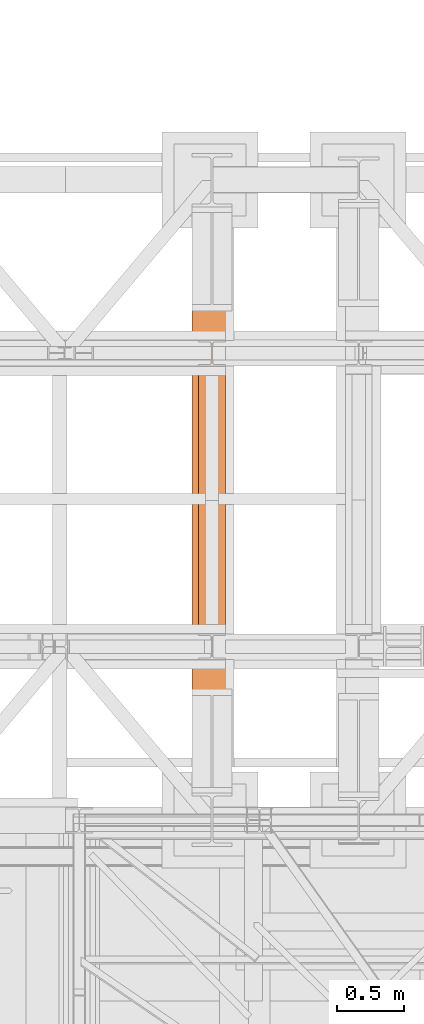
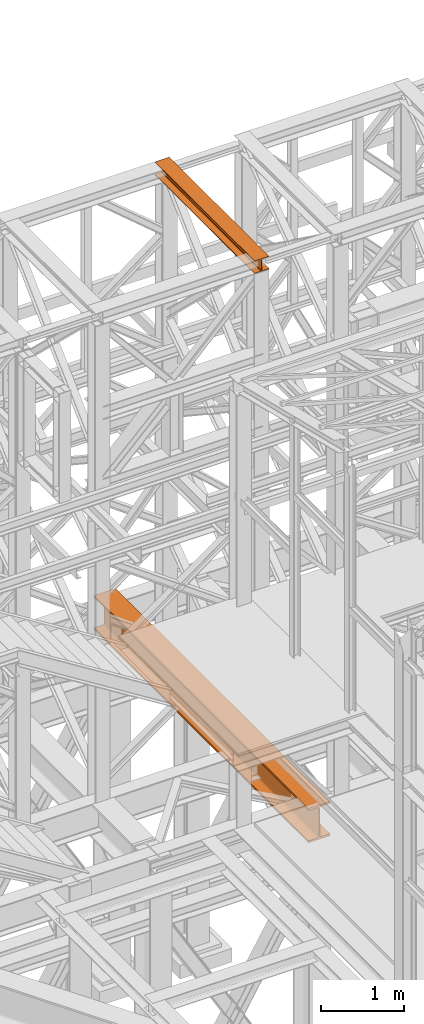
# One storey, part 121 of 208: 2 proxies.
"""IFC2X3 building model written with IfcOpenShell, lengths in millimetres."""

from ifc_helpers import new_model, entity, si_unit, converted_unit, frame, origin, origin_with_axes, place, context, subcontext, project, spatial, faceted_brep, element, save


model = new_model("IFC2X3")

# Units and contexts
model_context = context("Model", 3, precision=1e-05, world=origin())
plan_context = context("Plan", 3, precision=1e-05, world=origin())
body_context = subcontext(model_context, "Body", "Model", "MODEL_VIEW")
ifc_project = project(units=[si_unit("LENGTHUNIT", "METRE", prefix="MILLI"), converted_unit("PLANEANGLEUNIT", "DEGREE", entity("IfcPlaneAngleMeasure", 0.0174532925199433), si_unit("PLANEANGLEUNIT", "RADIAN"), dimensions=[0, 0, 0, 0, 0, 0, 0]), si_unit("AREAUNIT", "SQUARE_METRE"), si_unit("VOLUMEUNIT", "CUBIC_METRE")], contexts=[model_context, plan_context])

# Building, storey
building_placement = place(None, origin())
building = spatial("IfcBuilding", under=ifc_project, at=building_placement, CompositionType="COMPLEX")
storey_placement = place(building_placement, origin_with_axes())
storey = spatial("IfcBuildingStorey", under=building, at=storey_placement, Name="Geschoss", CompositionType="ELEMENT")

# Proxies
proxy_1_placement = place(storey_placement, frame((2043.254974489131, -17432.57439531566, 4784.990005364415), z_axis=(0.0, 0.0, 1.0), x_axis=(1.0, 0.0, 0.0)))
element("IfcBuildingElementProxy", 1, at=proxy_1_placement, inside=storey, context=body_context, shape_type="Brep", body=[
    faceted_brep([(300.0100000000002, 0.01000000000203727, 500.0100000000002), (300.0100000000007, 5140.010003576277, 500.0100000000002), (300.0100000000007, 5140.010003576277, 472.0100000000002), (300.0100000000002, 0.01000000000203727, 472.0100000000002), (300.0100000000002, 0.01000000000203727, 472.0100000000002), (300.0100000000007, 5140.010003576277, 472.0100000000002), (184.2600000000007, 5140.010003576277, 472.0100000000002), (184.2600000000002, 0.01000000000203727, 472.0100000000002), (184.2600000000002, 0.01000000000203727, 472.0100000000002), (184.2600000000007, 5140.010003576277, 472.0100000000002), (177.271909219226, 5140.010003576277, 471.0899181875066), (177.2719092192256, 0.01000000000203727, 471.0899181875066), (177.2719092192256, 0.01000000000203727, 471.0899181875066), (177.271909219226, 5140.010003576277, 471.0899181875066), (170.7600393754606, 5140.010003576277, 468.3926133818113), (170.7600393754601, 0.01000000000203727, 468.3926133818113), (170.7600393754601, 0.01000000000203727, 468.3926133818113), (170.7600393754606, 5140.010003576277, 468.3926133818113), (165.1681169079661, 5140.010003576277, 464.1018830920375), (165.1681169079657, 0.01000000000203727, 464.1018830920366), (165.1681169079657, 0.01000000000203727, 464.1018830920366), (165.1681169079661, 5140.010003576277, 464.1018830920375), (160.8773866181896, 5140.010003576277, 458.5099606245422), (160.8773866181891, 0.01000000000203727, 458.5099606245422), (160.8773866181891, 0.01000000000203727, 458.5099606245422), (160.8773866181896, 5140.010003576277, 458.5099606245422), (158.1800818124962, 5140.010003576277, 451.9980907807767), (158.1800818124957, 0.01000000000203727, 451.9980907807767), (158.1800818124957, 0.01000000000203727, 451.9980907807767), (158.1800818124962, 5140.010003576277, 451.9980907807767), (157.2600000000007, 5140.010003576277, 445.0100000000002), (157.2600000000002, 0.01000000000203727, 445.0100000000002), (157.2600000000002, 0.01000000000203727, 445.0100000000002), (157.2600000000007, 5140.010003576277, 445.0100000000002), (157.2600000000007, 5140.010003576277, 55.01000000000022), (157.2600000000002, 0.01000000000203727, 55.01000000000022), (157.2600000000002, 0.01000000000203727, 55.01000000000022), (157.2600000000007, 5140.010003576277, 55.01000000000022), (158.5815660577414, 5140.010003576277, 46.66656945413979), (158.5815660577409, 0.01000000000203727, 46.66656945413979), (158.5815660577409, 0.01000000000203727, 46.66656945413979), (158.5815660577414, 5140.010003576277, 46.66656945413979), (162.4165745365995, 5140.010003576277, 39.13982493419917), (162.416574536599, 0.01000000000203727, 39.13982493419917), (162.416574536599, 0.01000000000203727, 39.13982493419917), (162.4165745365995, 5140.010003576277, 39.13982493419917), (168.3898249342005, 5140.010003576277, 33.16657453659809), (168.3898249342001, 0.01000000000203727, 33.16657453659809), (168.3898249342001, 0.01000000000203727, 33.16657453659809), (168.3898249342005, 5140.010003576277, 33.16657453659809), (175.9165694541393, 5140.010003576277, 29.33156605774093), (175.9165694541389, 0.01000000000203727, 29.33156605774093), (175.9165694541389, 0.01000000000203727, 29.33156605774093), (175.9165694541393, 5140.010003576277, 29.33156605774093), (184.2600000000007, 5140.010003576277, 28.01000000000022), (184.2600000000002, 0.01000000000203727, 28.01000000000022), (184.2600000000002, 0.01000000000203727, 28.01000000000022), (184.2600000000007, 5140.010003576277, 28.01000000000022), (300.0100000000007, 5140.010003576277, 28.01000000000022), (300.0100000000002, 0.01000000000203727, 28.01000000000022), (300.0100000000002, 0.01000000000203727, 28.01000000000022), (300.0100000000007, 5140.010003576277, 28.01000000000022), (300.0100000000007, 5140.010003576277, 0.01000000000021828), (300.0100000000002, 0.01000000000203727, 0.01000000000021828), (300.0100000000002, 0.01000000000203727, 0.01000000000021828), (300.0100000000007, 5140.010003576277, 0.01000000000021828), (0.0100000000009004, 5140.010003576277, 0.01000000000021828), (0.01000000000021828, 0.01000000000203727, 0.01000000000021828), (0.01000000000021828, 0.01000000000203727, 0.01000000000021828), (0.0100000000009004, 5140.010003576277, 0.01000000000021828), (0.0100000000009004, 5140.010003576277, 28.01000000000022), (0.01000000000021828, 0.01000000000203727, 28.01000000000022), (0.01000000000021828, 0.01000000000203727, 28.01000000000022), (0.0100000000009004, 5140.010003576277, 28.01000000000022), (115.7600000000007, 5140.010003576277, 28.01000000000022), (115.7600000000002, 0.01000000000203727, 28.01000000000022), (115.7600000000002, 0.01000000000203727, 28.01000000000022), (115.7600000000007, 5140.010003576277, 28.01000000000022), (124.103430545862, 5140.010003576277, 29.33156605774093), (124.1034305458616, 0.01000000000203727, 29.33156605774093), (124.1034305458616, 0.01000000000203727, 29.33156605774093), (124.103430545862, 5140.010003576277, 29.33156605774093), (131.6301750658045, 5140.010003576277, 33.16657453659809), (131.630175065804, 0.01000000000203727, 33.16657453659809), (131.630175065804, 0.01000000000203727, 33.16657453659809), (131.6301750658045, 5140.010003576277, 33.16657453659809), (137.6034254634019, 5140.010003576277, 39.13982493419917), (137.6034254634014, 0.01000000000203727, 39.13982493419917), (137.6034254634014, 0.01000000000203727, 39.13982493419917), (137.6034254634019, 5140.010003576277, 39.13982493419917), (141.43843394226, 5140.010003576277, 46.66656945413979), (141.4384339422595, 0.01000000000203727, 46.66656945413979), (141.4384339422595, 0.01000000000203727, 46.66656945413979), (141.43843394226, 5140.010003576277, 46.66656945413979), (142.7600000000007, 5140.010003576277, 55.01000000000022), (142.7600000000002, 0.01000000000203727, 55.01000000000022), (142.7600000000002, 0.01000000000203727, 55.01000000000022), (142.7600000000007, 5140.010003576277, 55.01000000000022), (142.7600000000007, 5140.010003576277, 445.0100000000002), (142.7600000000002, 0.01000000000203727, 445.0100000000002), (142.7600000000002, 0.01000000000203727, 445.0100000000002), (142.7600000000007, 5140.010003576277, 445.0100000000002), (141.43843394226, 5140.010003576277, 453.3534305458607), (141.4384339422595, 0.01000000000203727, 453.3534305458607), (141.4384339422595, 0.01000000000203727, 453.3534305458607), (141.43843394226, 5140.010003576277, 453.3534305458607), (137.6034254634019, 5140.010003576277, 460.8801750658022), (137.6034254634014, 0.01000000000203727, 460.8801750658013), (137.6034254634014, 0.01000000000203727, 460.8801750658013), (137.6034254634019, 5140.010003576277, 460.8801750658022), (131.6301750658045, 5140.010003576277, 466.8534254634024), (131.630175065804, 0.01000000000203727, 466.8534254634024), (131.630175065804, 0.01000000000203727, 466.8534254634024), (131.6301750658045, 5140.010003576277, 466.8534254634024), (124.103430545862, 5140.010003576277, 470.6884339422595), (124.1034305458616, 0.01000000000203727, 470.6884339422595), (124.1034305458616, 0.01000000000203727, 470.6884339422595), (124.103430545862, 5140.010003576277, 470.6884339422595), (115.7600000000007, 5140.010003576277, 472.0100000000002), (115.7600000000002, 0.01000000000203727, 472.0100000000002), (115.7600000000002, 0.01000000000203727, 472.0100000000002), (115.7600000000007, 5140.010003576277, 472.0100000000002), (0.0100000000009004, 5140.010003576277, 472.0100000000002), (0.01000000000021828, 0.01000000000203727, 472.0100000000002), (0.01000000000021828, 0.01000000000203727, 472.0100000000002), (0.0100000000009004, 5140.010003576277, 472.0100000000002), (0.0100000000009004, 5140.010003576277, 500.0100000000002), (0.01000000000021828, 0.01000000000203727, 500.0100000000002), (0.01000000000021828, 0.01000000000203727, 500.0100000000002), (0.0100000000009004, 5140.010003576277, 500.0100000000002), (300.0100000000007, 5140.010003576277, 500.0100000000002), (300.0100000000002, 0.01000000000203727, 500.0100000000002), (300.0100000000002, 0.01000000000203727, 500.0100000000002), (300.0100000000002, 0.01000000000203727, 472.0100000000002), (184.2600000000002, 0.01000000000203727, 472.0100000000002), (177.2719092192256, 0.01000000000203727, 471.0899181875066), (170.7600393754601, 0.01000000000203727, 468.3926133818113), (165.1681169079657, 0.01000000000203727, 464.1018830920366), (160.8773866181891, 0.01000000000203727, 458.5099606245422), (158.1800818124957, 0.01000000000203727, 451.9980907807767), (157.2600000000002, 0.01000000000203727, 445.0100000000002), (157.2600000000002, 0.01000000000203727, 55.01000000000022), (158.5815660577409, 0.01000000000203727, 46.66656945413979), (162.416574536599, 0.01000000000203727, 39.13982493419917), (168.3898249342001, 0.01000000000203727, 33.16657453659809), (175.9165694541389, 0.01000000000203727, 29.33156605774093), (184.2600000000002, 0.01000000000203727, 28.01000000000022), (300.0100000000002, 0.01000000000203727, 28.01000000000022), (300.0100000000002, 0.01000000000203727, 0.01000000000021828), (0.01000000000021828, 0.01000000000203727, 0.01000000000021828), (0.01000000000021828, 0.01000000000203727, 28.01000000000022), (115.7600000000002, 0.01000000000203727, 28.01000000000022), (124.1034305458616, 0.01000000000203727, 29.33156605774093), (131.630175065804, 0.01000000000203727, 33.16657453659809), (137.6034254634014, 0.01000000000203727, 39.13982493419917), (141.4384339422595, 0.01000000000203727, 46.66656945413979), (142.7600000000002, 0.01000000000203727, 55.01000000000022), (142.7600000000002, 0.01000000000203727, 445.0100000000002), (141.4384339422595, 0.01000000000203727, 453.3534305458607), (137.6034254634014, 0.01000000000203727, 460.8801750658013), (131.630175065804, 0.01000000000203727, 466.8534254634024), (124.1034305458616, 0.01000000000203727, 470.6884339422595), (115.7600000000002, 0.01000000000203727, 472.0100000000002), (0.01000000000021828, 0.01000000000203727, 472.0100000000002), (0.01000000000021828, 0.01000000000203727, 500.0100000000002), (300.0100000000007, 5140.010003576277, 500.0100000000002), (0.0100000000009004, 5140.010003576277, 500.0100000000002), (0.0100000000009004, 5140.010003576277, 472.0100000000002), (115.7600000000007, 5140.010003576277, 472.0100000000002), (124.103430545862, 5140.010003576277, 470.6884339422595), (131.6301750658045, 5140.010003576277, 466.8534254634024), (137.6034254634019, 5140.010003576277, 460.8801750658022), (141.43843394226, 5140.010003576277, 453.3534305458607), (142.7600000000007, 5140.010003576277, 445.0100000000002), (142.7600000000007, 5140.010003576277, 55.01000000000022), (141.43843394226, 5140.010003576277, 46.66656945413979), (137.6034254634019, 5140.010003576277, 39.13982493419917), (131.6301750658045, 5140.010003576277, 33.16657453659809), (124.103430545862, 5140.010003576277, 29.33156605774093), (115.7600000000007, 5140.010003576277, 28.01000000000022), (0.0100000000009004, 5140.010003576277, 28.01000000000022), (0.0100000000009004, 5140.010003576277, 0.01000000000021828), (300.0100000000007, 5140.010003576277, 0.01000000000021828), (300.0100000000007, 5140.010003576277, 28.01000000000022), (184.2600000000007, 5140.010003576277, 28.01000000000022), (175.9165694541393, 5140.010003576277, 29.33156605774093), (168.3898249342005, 5140.010003576277, 33.16657453659809), (162.4165745365995, 5140.010003576277, 39.13982493419917), (158.5815660577414, 5140.010003576277, 46.66656945413979), (157.2600000000007, 5140.010003576277, 55.01000000000022), (157.2600000000007, 5140.010003576277, 445.0100000000002), (158.1800818124962, 5140.010003576277, 451.9980907807767), (160.8773866181896, 5140.010003576277, 458.5099606245422), (165.1681169079661, 5140.010003576277, 464.1018830920375), (170.7600393754606, 5140.010003576277, 468.3926133818113), (177.271909219226, 5140.010003576277, 471.0899181875066), (184.2600000000007, 5140.010003576277, 472.0100000000002), (300.0100000000007, 5140.010003576277, 472.0100000000002)], [[[0, 1, 2, 3]], [[4, 5, 6, 7]], [[8, 9, 10, 11]], [[12, 13, 14, 15]], [[16, 17, 18, 19]], [[20, 21, 22, 23]], [[24, 25, 26, 27]], [[28, 29, 30, 31]], [[32, 33, 34, 35]], [[36, 37, 38, 39]], [[40, 41, 42, 43]], [[44, 45, 46, 47]], [[48, 49, 50, 51]], [[52, 53, 54, 55]], [[56, 57, 58, 59]], [[60, 61, 62, 63]], [[64, 65, 66, 67]], [[68, 69, 70, 71]], [[72, 73, 74, 75]], [[76, 77, 78, 79]], [[80, 81, 82, 83]], [[84, 85, 86, 87]], [[88, 89, 90, 91]], [[92, 93, 94, 95]], [[96, 97, 98, 99]], [[100, 101, 102, 103]], [[104, 105, 106, 107]], [[108, 109, 110, 111]], [[112, 113, 114, 115]], [[116, 117, 118, 119]], [[120, 121, 122, 123]], [[124, 125, 126, 127]], [[128, 129, 130, 131]], [[132, 133, 134, 135, 136, 137, 138, 139, 140, 141, 142, 143, 144, 145, 146, 147, 148, 149, 150, 151, 152, 153, 154, 155, 156, 157, 158, 159, 160, 161, 162, 163, 164]], [[165, 166, 167, 168, 169, 170, 171, 172, 173, 174, 175, 176, 177, 178, 179, 180, 181, 182, 183, 184, 185, 186, 187, 188, 189, 190, 191, 192, 193, 194, 195, 196, 197]]], orient=[[False], [False], [False], [False], [False], [False], [False], [False], [False], [False], [False], [False], [False], [False], [False], [False], [False], [False], [False], [False], [False], [False], [False], [False], [False], [False], [False], [False], [False], [False], [False], [False], [False], [False], [False]]),
])
proxy_2_placement = place(storey_placement, frame((2093.254967038549, -16057.57439657637, 12249.99005869381), z_axis=(0.0, 0.0, 1.0), x_axis=(1.0, 0.0, 0.0)))
element("IfcBuildingElementProxy", 2, at=proxy_2_placement, inside=storey, context=body_context, shape_type="Brep", body=[
    faceted_brep([(0.01000000000021828, 2390.010012516976, 0.01000000000021828), (200.0100029802325, 2390.010012516976, 0.01000000000021828), (200.0100029802325, 2390.010012516976, 10.00999791383765), (121.2600035762789, 2390.010012516976, 10.01000536441825), (111.9441915473344, 2390.010012516976, 11.87455041170142), (105.1245498640838, 2390.010012516976, 18.69419349193595), (103.2600015571716, 2390.010012516976, 28.01000458955787), (103.2600015571716, 2390.010012516976, 162.0100153779986), (105.1245498640838, 2390.010012516976, 171.3258264756205), (111.9441915473344, 2390.010012516976, 178.145469555855), (121.2600035762789, 2390.010012516976, 180.0100146031382), (200.0100029802325, 2390.010012516976, 180.0100146031382), (200.0100029802325, 2390.010012516976, 190.0100125169756), (0.01000000000021828, 2390.010012516976, 190.0100125169756), (0.01000000000021828, 2390.010012516976, 180.0100146031382), (78.75999940395377, 2390.010012516976, 180.0100146031382), (88.07581143289826, 2390.010012516976, 178.145469555855), (94.89545311614893, 2390.010012516976, 171.3258264756205), (96.76000142306111, 2390.010012516976, 162.0100153779986), (96.76000142306111, 2390.010012516976, 28.01000458955787), (94.89545311614893, 2390.010012516976, 18.69419349193595), (88.07581143289826, 2390.010012516976, 11.87455041170142), (78.75999940395377, 2390.010012516976, 10.01000536441825), (0.01000000000021828, 2390.010012516976, 10.00999791383765), (200.0100029802325, 2390.010012516976, 0.01000000000021828), (0.01000000000021828, 2390.010012516976, 0.01000000000021828), (0.01000000000021828, 0.00999999999839929, 0.01000000000021828), (200.0100029802325, 0.00999999999839929, 0.01000000000021828), (200.0100029802325, 2390.010012516976, 10.00999791383765), (200.0100029802325, 2390.010012516976, 0.01000000000021828), (200.0100029802325, 0.00999999999839929, 0.01000000000021828), (200.0100029802325, 0.00999999999839929, 10.00999791383765), (121.2600035762789, 2390.010012516976, 10.01000536441825), (200.0100029802325, 2390.010012516976, 10.00999791383765), (200.0100029802325, 0.00999999999839929, 10.00999791383765), (121.2600035762789, 0.00999999999839929, 10.01000536441825), (111.9441915473344, 2390.010012516976, 11.87455041170142), (121.2600035762789, 2390.010012516976, 10.01000536441825), (121.2600035762789, 0.00999999999839929, 10.01000536441825), (111.9441915473344, 0.00999999999839929, 11.87455041170142), (105.1245498640838, 2390.010012516976, 18.69419349193595), (111.9441915473344, 2390.010012516976, 11.87455041170142), (111.9441915473344, 0.00999999999839929, 11.87455041170142), (105.1245498640838, 0.00999999999839929, 18.69419349193595), (103.2600015571716, 2390.010012516976, 28.01000458955787), (105.1245498640838, 2390.010012516976, 18.69419349193595), (105.1245498640838, 0.00999999999839929, 18.69419349193595), (103.2600015571716, 0.00999999999839929, 28.01000458955787), (103.2600015571716, 2390.010012516976, 162.0100153779986), (103.2600015571716, 2390.010012516976, 28.01000458955787), (103.2600015571716, 0.00999999999839929, 28.01000458955787), (103.2600015571716, 0.00999999999839929, 162.0100153779986), (105.1245498640838, 2390.010012516976, 171.3258264756205), (103.2600015571716, 2390.010012516976, 162.0100153779986), (103.2600015571716, 0.00999999999839929, 162.0100153779986), (105.1245498640838, 0.00999999999839929, 171.3258264756205), (111.9441915473344, 2390.010012516976, 178.145469555855), (105.1245498640838, 2390.010012516976, 171.3258264756205), (105.1245498640838, 0.00999999999839929, 171.3258264756205), (111.9441915473344, 0.00999999999839929, 178.145469555855), (121.2600035762789, 2390.010012516976, 180.0100146031382), (111.9441915473344, 2390.010012516976, 178.145469555855), (111.9441915473344, 0.00999999999839929, 178.145469555855), (121.2600035762789, 0.00999999999839929, 180.0100146031382), (200.0100029802325, 2390.010012516976, 180.0100146031382), (121.2600035762789, 2390.010012516976, 180.0100146031382), (121.2600035762789, 0.00999999999839929, 180.0100146031382), (200.0100029802325, 0.00999999999839929, 180.0100146031382), (200.0100029802325, 2390.010012516976, 190.0100125169756), (200.0100029802325, 2390.010012516976, 180.0100146031382), (200.0100029802325, 0.00999999999839929, 180.0100146031382), (200.0100029802325, 0.00999999999839929, 190.0100125169756), (0.01000000000021828, 2390.010012516976, 190.0100125169756), (200.0100029802325, 2390.010012516976, 190.0100125169756), (200.0100029802325, 0.00999999999839929, 190.0100125169756), (0.01000000000021828, 0.00999999999839929, 190.0100125169756), (0.01000000000021828, 2390.010012516976, 180.0100146031382), (0.01000000000021828, 2390.010012516976, 190.0100125169756), (0.01000000000021828, 0.00999999999839929, 190.0100125169756), (0.01000000000021828, 0.00999999999839929, 180.0100146031382), (78.75999940395377, 2390.010012516976, 180.0100146031382), (0.01000000000021828, 2390.010012516976, 180.0100146031382), (0.01000000000021828, 0.00999999999839929, 180.0100146031382), (78.75999940395377, 0.00999999999839929, 180.0100146031382), (88.07581143289826, 2390.010012516976, 178.145469555855), (78.75999940395377, 2390.010012516976, 180.0100146031382), (78.75999940395377, 0.00999999999839929, 180.0100146031382), (88.07581143289826, 0.00999999999839929, 178.145469555855), (94.89545311614893, 2390.010012516976, 171.3258264756205), (88.07581143289826, 2390.010012516976, 178.145469555855), (88.07581143289826, 0.00999999999839929, 178.145469555855), (94.89545311614893, 0.00999999999839929, 171.3258264756205), (96.76000142306111, 2390.010012516976, 162.0100153779986), (94.89545311614893, 2390.010012516976, 171.3258264756205), (94.89545311614893, 0.00999999999839929, 171.3258264756205), (96.76000142306111, 0.00999999999839929, 162.0100153779986), (96.76000142306111, 2390.010012516976, 28.01000458955787), (96.76000142306111, 2390.010012516976, 162.0100153779986), (96.76000142306111, 0.00999999999839929, 162.0100153779986), (96.76000142306111, 0.00999999999839929, 28.01000458955787), (94.89545311614893, 2390.010012516976, 18.69419349193595), (96.76000142306111, 2390.010012516976, 28.01000458955787), (96.76000142306111, 0.00999999999839929, 28.01000458955787), (94.89545311614893, 0.00999999999839929, 18.69419349193595), (88.07581143289826, 2390.010012516976, 11.87455041170142), (94.89545311614893, 2390.010012516976, 18.69419349193595), (94.89545311614893, 0.00999999999839929, 18.69419349193595), (88.07581143289826, 0.00999999999839929, 11.87455041170142), (78.75999940395377, 2390.010012516976, 10.01000536441825), (88.07581143289826, 2390.010012516976, 11.87455041170142), (88.07581143289826, 0.00999999999839929, 11.87455041170142), (78.75999940395377, 0.00999999999839929, 10.01000536441825), (0.01000000000021828, 2390.010012516976, 10.00999791383765), (78.75999940395377, 2390.010012516976, 10.01000536441825), (78.75999940395377, 0.00999999999839929, 10.01000536441825), (0.01000000000021828, 0.00999999999839929, 10.00999791383765), (0.01000000000021828, 2390.010012516976, 0.01000000000021828), (0.01000000000021828, 2390.010012516976, 10.00999791383765), (0.01000000000021828, 0.00999999999839929, 10.00999791383765), (0.01000000000021828, 0.00999999999839929, 0.01000000000021828), (0.01000000000021828, 0.00999999999839929, 0.01000000000021828), (0.01000000000021828, 0.00999999999839929, 10.00999791383765), (78.75999940395377, 0.00999999999839929, 10.01000536441825), (88.07581143289826, 0.00999999999839929, 11.87455041170142), (94.89545311614893, 0.00999999999839929, 18.69419349193595), (96.76000142306111, 0.00999999999839929, 28.01000458955787), (96.76000142306111, 0.00999999999839929, 162.0100153779986), (94.89545311614893, 0.00999999999839929, 171.3258264756205), (88.07581143289826, 0.00999999999839929, 178.145469555855), (78.75999940395377, 0.00999999999839929, 180.0100146031382), (0.01000000000021828, 0.00999999999839929, 180.0100146031382), (0.01000000000021828, 0.00999999999839929, 190.0100125169756), (200.0100029802325, 0.00999999999839929, 190.0100125169756), (200.0100029802325, 0.00999999999839929, 180.0100146031382), (121.2600035762789, 0.00999999999839929, 180.0100146031382), (111.9441915473344, 0.00999999999839929, 178.145469555855), (105.1245498640838, 0.00999999999839929, 171.3258264756205), (103.2600015571716, 0.00999999999839929, 162.0100153779986), (103.2600015571716, 0.00999999999839929, 28.01000458955787), (105.1245498640838, 0.00999999999839929, 18.69419349193595), (111.9441915473344, 0.00999999999839929, 11.87455041170142), (121.2600035762789, 0.00999999999839929, 10.01000536441825), (200.0100029802325, 0.00999999999839929, 10.00999791383765), (200.0100029802325, 0.00999999999839929, 0.01000000000021828)], [[[0, 1, 2, 3, 4, 5, 6, 7, 8, 9, 10, 11, 12, 13, 14, 15, 16, 17, 18, 19, 20, 21, 22, 23]], [[24, 25, 26, 27]], [[28, 29, 30, 31]], [[32, 33, 34, 35]], [[36, 37, 38, 39]], [[40, 41, 42, 43]], [[44, 45, 46, 47]], [[48, 49, 50, 51]], [[52, 53, 54, 55]], [[56, 57, 58, 59]], [[60, 61, 62, 63]], [[64, 65, 66, 67]], [[68, 69, 70, 71]], [[72, 73, 74, 75]], [[76, 77, 78, 79]], [[80, 81, 82, 83]], [[84, 85, 86, 87]], [[88, 89, 90, 91]], [[92, 93, 94, 95]], [[96, 97, 98, 99]], [[100, 101, 102, 103]], [[104, 105, 106, 107]], [[108, 109, 110, 111]], [[112, 113, 114, 115]], [[116, 117, 118, 119]], [[120, 121, 122, 123, 124, 125, 126, 127, 128, 129, 130, 131, 132, 133, 134, 135, 136, 137, 138, 139, 140, 141, 142, 143]]], orient=[[False], [False], [False], [False], [False], [False], [False], [False], [False], [False], [False], [False], [False], [False], [False], [False], [False], [False], [False], [False], [False], [False], [False], [False], [False], [False]]),
])

save(model, "model.ifc")
